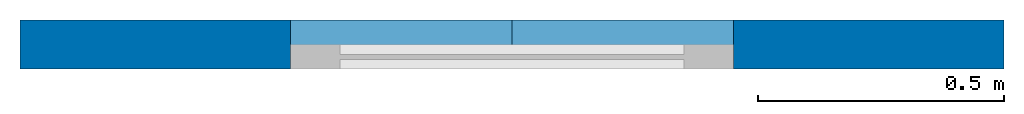
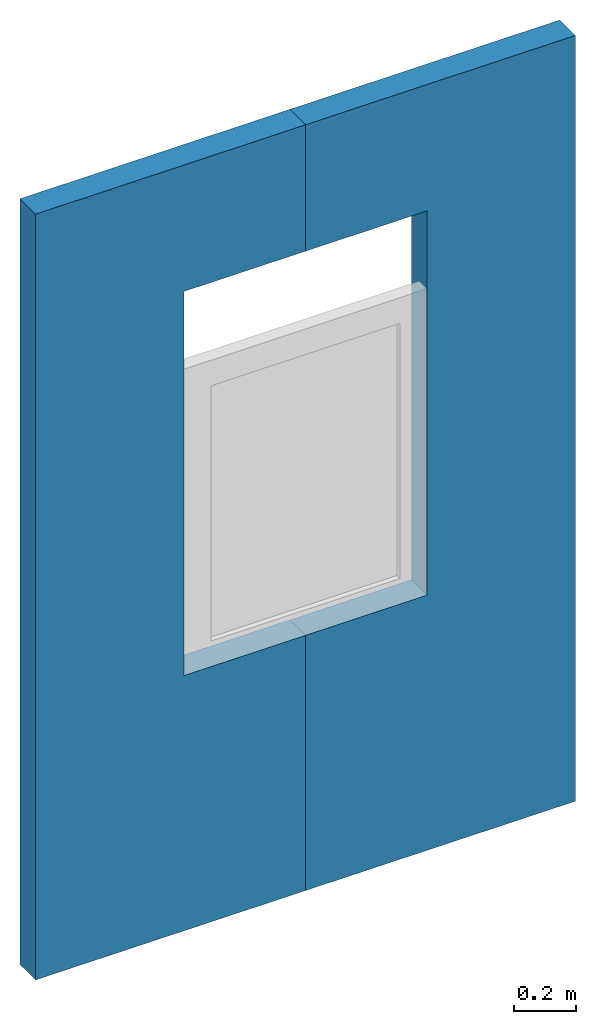
# One storey, part 1 of 2: 2 walls, 1 opening, 1 element without a shape of its own.
"""IFC4 building model written with IfcOpenShell, lengths in feet."""

from ifc_helpers import new_model, entity, si_unit, converted_unit, frame, origin_with_axes, origin_2d_with_axis, place, context, subcontext, project, spatial, line, indexed_curve, outline, extrude, source, transform, mapped, material, layer, layer_set, layer_usage, type_object, element, aggregate, save


model = new_model("IFC4")

# Units and contexts
model_context = context("Model", 3, precision=1e-05, world=origin_with_axes())
plan_context = context("Plan", 2, precision=1e-05, world=origin_2d_with_axis())
body_context = subcontext(model_context, "Body", "Model", "MODEL_VIEW")
ifc_project = project(units=[converted_unit("PLANEANGLEUNIT", "degree", entity("IfcReal", 0.0174532925199433), si_unit("PLANEANGLEUNIT", "RADIAN"), dimensions=[0, 0, 0, 0, 0, 0, 0]), converted_unit("AREAUNIT", "square foot", entity("IfcReal", 0.09290304), si_unit("AREAUNIT", "SQUARE_METRE"), dimensions=[2, 0, 0, 0, 0, 0, 0]), converted_unit("LENGTHUNIT", "foot", entity("IfcReal", 0.3048), si_unit("LENGTHUNIT", "METRE"), dimensions=[1, 0, 0, 0, 0, 0, 0]), converted_unit("VOLUMEUNIT", "cubic foot", entity("IfcReal", 0.0283168467116885), si_unit("VOLUMEUNIT", "CUBIC_METRE"), dimensions=[3, 0, 0, 0, 0, 0, 0])], contexts=[model_context, plan_context])

# Site, building, storey
site_placement = place(None, origin_with_axes())
site = spatial("IfcSite", under=ifc_project, at=site_placement)
building_placement = place(site_placement, origin_with_axes())
building = spatial("IfcBuilding", under=site, at=building_placement, Name="Building")
storey_placement = place(building_placement, origin_with_axes())
storey = spatial("IfcBuildingStorey", under=building, at=storey_placement, Name="Storey")

# Assembly, opening, walls
assembly_placement = place(storey_placement, frame((4.75721800421167, 0.0, 3.28083989501312), z_axis=(0.0, 0.0, 1.0), x_axis=(1.0, 0.0, 0.0)))
assembly = element("IfcElementAssembly", 1, at=assembly_placement, inside=storey, Name="Assembly")
shared_shape = source(origin_with_axes(), body_context, "Body", "SweptSolid", [
    extrude(outline(indexed_curve([(0.0, 0.0), (2.95275592803955, 0.0), (2.95275592803955, 4.93700838088989), (0.0, 4.93700838088989)], segments=[line(1, 2, 3, 4, 1)])), frame((0.0, -1.96850395202637, 0.0), z_axis=(0.0, -1.0, 0.0), x_axis=(1.0, 0.0, 0.0)), (0.0, 0.0, -1.0), 3.93700787401575),
])
opening_placement = place(assembly_placement, frame((-6.23359611341021, 0.0, 0.0), z_axis=(0.0, 0.0, 1.0), x_axis=(1.0, 0.0, 0.0)))
element("IfcOpeningElement", 2, at=opening_placement, cuts=assembly, PredefinedType="OPENING", context=body_context, shape_type="MappedRepresentation", body=[
    mapped(shared_shape, transform((0.0, 0.0, 0.0), x_axis=(1.0, 0.0, 0.0), y_axis=(0.0, 1.0, 0.0), z_axis=(0.0, 0.0, 1.0), scale=1.0)),
])
ifc_material = material()
ifc_layer = layer(ifc_material, 0.328083989501312)
ifc_layer_set = layer_set([ifc_layer])
ifc_layer_usage_1 = layer_usage(ifc_layer_set, "AXIS2", "POSITIVE", 0.0)
wall_type = type_object("IfcWallType", Name="WAL100", PredefinedType="NOTDEFINED", material=ifc_layer_set)
wall_1_placement = place(assembly_placement, frame((-4.75721800421167, 0.0, -3.28083989501312), z_axis=(0.0, 0.0, 1.0), x_axis=(1.0, 0.0, 0.0)))
wall_1 = element("IfcWall", 3, at=wall_1_placement, type_object=wall_type, material=ifc_layer_usage_1, Name="Wall", context=body_context, shape_type="SweptSolid", body=[
    extrude(outline(indexed_curve([(0.0, 0.0), (0.0, 0.328083989501312), (3.28083989501312, 0.328083989501312), (3.28083989501312, 0.0), (0.0, 0.0)], self_intersect=False)), origin_with_axes(), (0.0, 0.0, 1.0), 9.84251968503937),
])
ifc_layer_usage_2 = layer_usage(ifc_layer_set, "AXIS2", "POSITIVE", 0.0)
wall_2_placement = place(assembly_placement, frame((-8.03805789922479, 0.0, -3.28083989501312), z_axis=(0.0, 0.0, 1.0), x_axis=(1.0, 0.0, 0.0)))
wall_2 = element("IfcWall", 4, at=wall_2_placement, type_object=wall_type, material=ifc_layer_usage_2, Name="Wall", context=body_context, shape_type="SweptSolid", body=[
    extrude(outline(indexed_curve([(0.0, 0.0), (0.0, 0.328083989501312), (3.28083989501312, 0.328083989501312), (3.28083989501312, 0.0), (0.0, 0.0)], self_intersect=False)), origin_with_axes(), (0.0, 0.0, 1.0), 9.84251968503937),
])
aggregate(assembly, [wall_1, wall_2])

save(model, "model.ifc")
